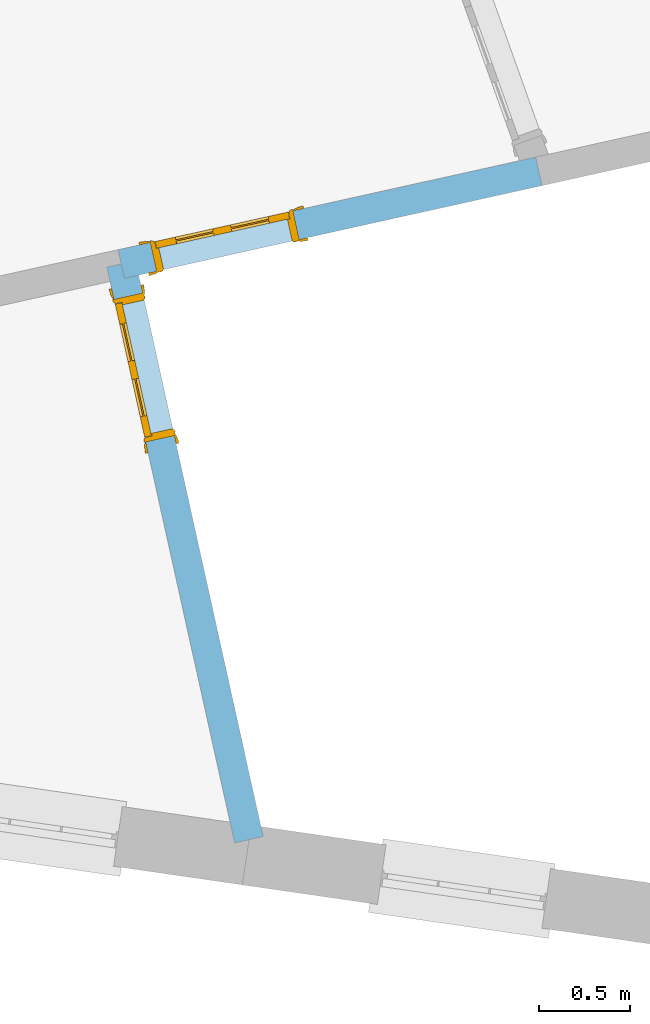
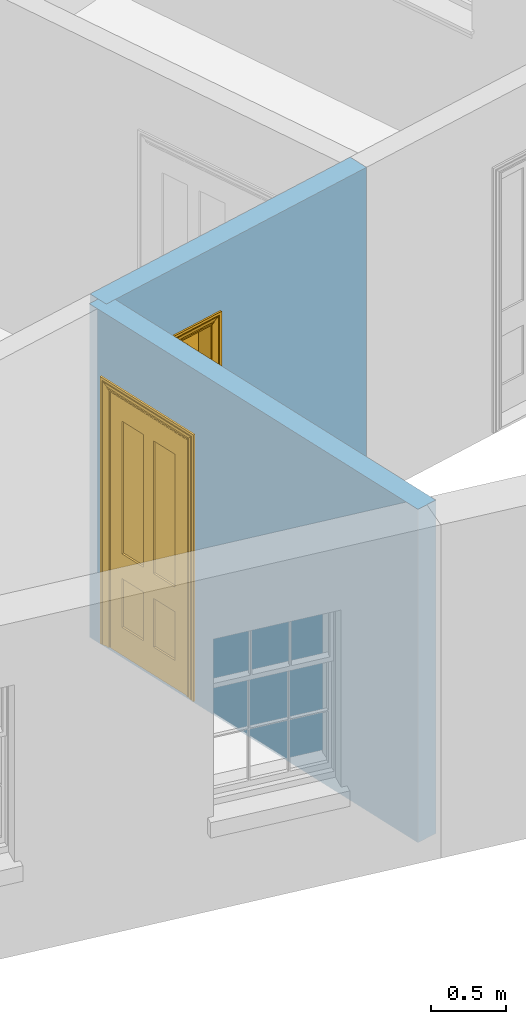
# One storey, part 6 of 11: 2 doors, 2 openings, plus 2 elements that do not belong to this part.
"""IFC2X3 building model written with IfcOpenShell, lengths in metres."""

from ifc_helpers import new_model, si_unit, frame, origin, place, context, subcontext, project, spatial, polyline, outline, extrude, faceted_brep, material, layer, layer_set, layer_usage, element, fill, save


model = new_model("IFC2X3")

# Units and contexts
model_context = context("Model", 3, world=origin())
body_context = subcontext(model_context, "Body", "Model", "MODEL_VIEW")
ifc_project = project(units=[si_unit("PLANEANGLEUNIT", "RADIAN"), si_unit("MASSUNIT", "GRAM", prefix="KILO"), si_unit("FORCEUNIT", "NEWTON", prefix="KILO"), si_unit("LENGTHUNIT", "METRE")], contexts=[model_context])

# Site, building, storey
site_placement = place(None, origin())
site = spatial("IfcSite", under=ifc_project, at=site_placement, CompositionType="ELEMENT")
building_placement = place(None, origin())
building = spatial("IfcBuilding", under=site, at=building_placement, Name="Building plot-16", CompositionType="ELEMENT")
storey_placement = place(None, frame((0.0, 0.0, 9.0)))
storey = spatial("IfcBuildingStorey", under=building, at=storey_placement, Name="Floor 2", CompositionType="ELEMENT", Elevation=9.0)

# Wall, opening, door
ifc_material = material(Name="Masonry")
ifc_layer = layer(ifc_material, 0.16, ventilated=False)
ifc_layer_set = layer_set([ifc_layer], Name="My Wall")
ifc_layer_usage = layer_usage(ifc_layer_set, "AXIS2", "NEGATIVE", 0.08)
wall_1_placement = place(storey_placement, origin())
wall_1 = element("IfcWallStandardCase", 1, at=wall_1_placement, inside=storey, material=ifc_layer_usage, Name="interior", context=body_context, shape_type="SweptSolid", body=[
    extrude(outline(polyline([(92.4243994850158, 31.3164839815775), (92.580604620015, 31.3511243597489), (91.8820901630794, 34.5009613651233), (91.7258850280802, 34.4663209869519), (92.4243994850158, 31.3164839815775)])), origin(), (0.0, 0.0, 1.0), 2.7),
])
opening_1_placement = place(storey_placement, frame((0.0, 0.0, 0.0199999999999996)))
opening_1 = element("IfcOpeningElement", 2, at=opening_1_placement, cuts=wall_1, Name="Opening", ObjectType="Opening", context=body_context, shape_type="SweptSolid", body=[
    extrude(outline(polyline([(92.0942624793795, 33.5442049132528), (91.9210605885223, 34.3252305882491), (91.764855453523, 34.2905902100777), (91.9380573443802, 33.5095645350814), (92.0942624793795, 33.5442049132528)])), origin(), (0.0, 0.0, 1.0), 2.1),
])
door_1_placement = place(storey_placement, frame((92.0161599118799, 33.5268847241671, 0.0199999999999996), z_axis=(0.0, 0.0, 1.0), x_axis=(-0.1732018908572, 0.781025674996343, 0.0)))
door_1 = element("IfcDoor", 3, at=door_1_placement, inside=storey, Name="toilet inside door", OverallHeight=2.1, OverallWidth=0.8, context=body_context, shape_type="Brep", held_by="IfcProductRepresentation", body=[
    faceted_brep([(0.773, 0.08, 1.895), (0.66, 0.08, 1.895), (0.66, 0.08, 2.073), (0.773, 0.08, 2.073), (0.773, 0.08, 0.82), (0.66, 0.08, 0.82), (0.45, 0.08, 1.895), (0.45, 0.08, 2.073), (0.773, 0.08, 0.62), (0.66, 0.08, 0.62), (0.66, 0.065, 0.82), (0.66, 0.065, 1.895), (0.45, 0.065, 1.895), (0.35, 0.08, 1.895), (0.35, 0.08, 2.073), (0.773, 0.08, 0.225), (0.66, 0.08, 0.225), (0.45, 0.08, 0.62), (0.45, 0.08, 0.82), (0.45, 0.065, 0.82), (0.35, 0.08, 0.82), (0.14, 0.08, 2.073), (0.14, 0.08, 1.895), (0.773, 0.08, 0.0), (0.66, 0.08, 0.0), (0.66, 0.065, 0.225), (0.66, 0.065, 0.62), (0.45, 0.065, 0.62), (0.35, 0.08, 0.62), (0.35, 0.065, 0.82), (0.35, 0.065, 1.895), (0.14, 0.065, 1.895), (0.027, 0.08, 2.073), (0.027, 0.08, 1.895), (0.773, 0.042, 0.0), (0.66, 0.042, 0.0), (0.45, 0.08, 0.0), (0.45, 0.08, 0.225), (0.45, 0.065, 0.225), (0.35, 0.08, 0.225), (0.14, 0.08, 0.82), (0.14, 0.08, 0.62), (0.14, 0.065, 0.82), (0.027, 0.08, 0.82), (0.773, 0.042, 0.225), (0.66, 0.042, 0.225), (0.45, 0.042, 0.0), (0.35, 0.08, 0.0), (0.35, 0.065, 0.225), (0.35, 0.065, 0.62), (0.14, 0.065, 0.62), (0.027, 0.08, 0.62), (0.773, 0.042, 0.62), (0.66, 0.042, 0.62), (0.45, 0.042, 0.225), (0.35, 0.042, 0.0), (0.14, 0.08, 0.225), (0.14, 0.08, 0.0), (0.14, 0.065, 0.225), (0.027, 0.08, 0.225), (0.773, 0.042, 0.82), (0.66, 0.042, 0.82), (0.66, 0.057, 0.62), (0.66, 0.057, 0.225), (0.45, 0.057, 0.225), (0.35, 0.042, 0.225), (0.14, 0.042, 0.0), (0.027, 0.08, 0.0), (0.773, 0.042, 1.895), (0.66, 0.042, 1.895), (0.45, 0.042, 0.62), (0.45, 0.042, 0.82), (0.45, 0.057, 0.62), (0.35, 0.042, 0.62), (0.14, 0.042, 0.225), (0.027, 0.042, 0.0), (0.773, 0.042, 2.073), (0.66, 0.042, 2.073), (0.66, 0.057, 1.895), (0.66, 0.057, 0.82), (0.45, 0.057, 0.82), (0.35, 0.042, 0.82), (0.35, 0.057, 0.62), (0.35, 0.057, 0.225), (0.14, 0.057, 0.225), (0.027, 0.042, 0.225), (0.45, 0.042, 1.895), (0.45, 0.042, 2.073), (0.45, 0.057, 1.895), (0.35, 0.042, 1.895), (0.14, 0.042, 0.82), (0.14, 0.042, 0.62), (0.14, 0.057, 0.62), (0.027, 0.042, 0.62), (0.35, 0.042, 2.073), (0.35, 0.057, 1.895), (0.35, 0.057, 0.82), (0.14, 0.057, 0.82), (0.027, 0.042, 0.82), (0.14, 0.042, 2.073), (0.14, 0.042, 1.895), (0.14, 0.057, 1.895), (0.027, 0.042, 1.895), (0.027, 0.042, 2.073), (0.02, 0.085, 0.0), (0.005, 0.09, 0.0), (0.005, 0.09, 2.095), (0.02, 0.085, 2.08), (0.02, 0.08, 0.0), (0.0, 0.085, 0.0), (0.0, 0.085, 2.1), (0.795, 0.09, 2.095), (0.78, 0.085, 2.08), (0.02, 0.08, 2.08), (0.0, 0.08, 0.0), (-0.032, 0.095, 0.0), (-0.032, 0.095, 2.132), (0.8, 0.085, 2.1), (0.795, 0.09, 0.0), (0.78, 0.085, 0.0), (0.78, 0.08, 2.08), (0.04, 0.04, 0.0), (0.025, 0.04, 0.0), (0.025, 0.04, 2.075), (0.04, 0.04, 2.06), (-0.04, 0.09, 0.0), (-0.04, 0.09, 2.14), (0.832, 0.095, 2.132), (0.8, 0.085, 0.0), (0.78, 0.08, 0.0), (0.8, 0.08, 0.0), (0.86, 0.08, 0.0), (0.86, 0.08, 2.16), (0.8, 0.08, 2.1), (-0.06, 0.08, 2.16), (0.0, 0.08, 2.1), (-0.06, 0.08, 0.0), (-0.04, 0.095, 0.0), (-0.04, 0.095, 2.14), (0.84, 0.09, 2.14), (0.832, 0.095, 0.0), (0.84, 0.09, 0.0), (0.86, 0.095, 0.0), (0.86, 0.095, 2.16), (-0.06, 0.095, 2.16), (-0.06, 0.095, 0.0), (0.84, 0.095, 0.0), (0.84, 0.095, 2.14), (-0.025, -0.095, 0.0), (-0.025, -0.09, 0.0), (-0.025, -0.09, 2.125), (-0.025, -0.095, 2.125), (-0.017, -0.095, 0.0), (-0.017, -0.095, 2.117), (0.825, -0.09, 2.125), (0.825, -0.095, 2.125), (0.825, -0.095, 0.0), (0.845, -0.095, 0.0), (-0.045, -0.095, 2.145), (-0.045, -0.095, 0.0), (0.845, -0.095, 2.145), (0.015, -0.085, 0.0), (0.015, -0.085, 2.085), (0.817, -0.095, 2.117), (0.825, -0.09, 0.0), (0.845, -0.08, 0.0), (0.845, -0.08, 2.145), (-0.045, -0.08, 2.145), (-0.045, -0.08, 0.0), (0.02, -0.09, 0.0), (0.02, -0.09, 2.08), (0.785, -0.085, 2.085), (0.817, -0.095, 0.0), (0.8, -0.08, 0.0), (0.8, -0.08, 2.1), (0.0, -0.08, 2.1), (0.0, -0.08, 0.0), (0.035, -0.085, 0.0), (0.035, -0.085, 2.065), (0.78, -0.09, 2.08), (0.785, -0.085, 0.0), (0.775, 0.04, 2.075), (0.76, 0.04, 2.06), (0.035, -0.08, 2.065), (0.035, -0.08, 0.0), (0.765, -0.085, 2.065), (0.78, -0.09, 0.0), (0.765, -0.08, 0.0), (0.765, -0.08, 2.065), (0.765, -0.085, 0.0), (0.04, -0.08, 2.06), (0.04, -0.08, 0.0), (0.76, -0.08, 2.06), (0.76, -0.08, 0.0), (0.76, 0.04, 0.0), (0.775, 0.04, 0.0), (0.025, 0.08, 0.0), (0.025, 0.08, 2.075), (0.775, 0.08, 0.0), (0.775, 0.08, 2.075)], [[[0, 1, 2, 3]], [[1, 0, 4, 5]], [[1, 6, 7, 2]], [[8, 9, 5, 4]], [[1, 5, 10, 11]], [[6, 1, 11, 12]], [[6, 13, 14, 7]], [[15, 16, 9, 8]], [[9, 17, 18, 5]], [[5, 18, 19, 10]], [[10, 19, 12, 11]], [[18, 6, 12, 19]], [[18, 20, 13, 6]], [[21, 14, 13, 22]], [[23, 24, 16, 15]], [[9, 16, 25, 26]], [[17, 9, 26, 27]], [[17, 28, 20, 18]], [[13, 20, 29, 30]], [[22, 13, 30, 31]], [[32, 21, 22, 33]], [[34, 35, 24, 23]], [[24, 36, 37, 16]], [[16, 37, 38, 25]], [[25, 38, 27, 26]], [[37, 17, 27, 38]], [[37, 39, 28, 17]], [[40, 20, 28, 41]], [[20, 40, 42, 29]], [[31, 30, 29, 42]], [[40, 22, 31, 42]], [[33, 22, 40, 43]], [[35, 34, 44, 45]], [[35, 46, 36, 24]], [[36, 47, 39, 37]], [[28, 39, 48, 49]], [[41, 28, 49, 50]], [[43, 40, 41, 51]], [[45, 44, 52, 53]], [[46, 35, 45, 54]], [[46, 55, 47, 36]], [[56, 39, 47, 57]], [[39, 56, 58, 48]], [[50, 49, 48, 58]], [[56, 41, 50, 58]], [[51, 41, 56, 59]], [[53, 52, 60, 61]], [[45, 53, 62, 63]], [[54, 45, 63, 64]], [[55, 46, 54, 65]], [[55, 66, 57, 47]], [[59, 56, 57, 67]], [[61, 60, 68, 69]], [[70, 53, 61, 71]], [[53, 70, 72, 62]], [[72, 64, 63, 62]], [[70, 54, 64, 72]], [[65, 54, 70, 73]], [[65, 74, 66, 55]], [[67, 57, 66, 75]], [[69, 68, 76, 77]], [[61, 69, 78, 79]], [[71, 61, 79, 80]], [[73, 70, 71, 81]], [[65, 73, 82, 83]], [[74, 65, 83, 84]], [[74, 85, 75, 66]], [[86, 69, 77, 87]], [[69, 86, 88, 78]], [[88, 80, 79, 78]], [[86, 71, 80, 88]], [[81, 71, 86, 89]], [[73, 81, 90, 91]], [[73, 91, 92, 82]], [[83, 82, 92, 84]], [[91, 74, 84, 92]], [[91, 93, 85, 74]], [[89, 86, 87, 94]], [[81, 89, 95, 96]], [[90, 81, 96, 97]], [[90, 98, 93, 91]], [[94, 99, 100, 89]], [[89, 100, 101, 95]], [[101, 97, 96, 95]], [[100, 90, 97, 101]], [[100, 102, 98, 90]], [[99, 103, 102, 100]], [[32, 103, 99, 21]], [[102, 103, 32, 33]], [[98, 102, 33, 43]], [[21, 99, 94, 14]], [[94, 87, 7, 14]], [[7, 87, 77, 2]], [[76, 3, 2, 77]], [[43, 51, 93, 98]], [[51, 59, 85, 93]], [[67, 75, 85, 59]], [[34, 23, 15, 44]], [[44, 15, 8, 52]], [[52, 8, 4, 60]], [[0, 68, 60, 4]], [[0, 3, 76, 68]], [[104, 105, 106, 107]], [[104, 108, 109, 105]], [[105, 109, 110, 106]], [[107, 106, 111, 112]], [[107, 113, 108, 104]], [[114, 109, 108]], [[109, 115, 116, 110]], [[106, 110, 117, 111]], [[112, 111, 118, 119]], [[113, 107, 112, 120]], [[121, 122, 123, 124]], [[115, 109, 114, 125]], [[115, 125, 126, 116]], [[110, 116, 127, 117]], [[111, 117, 128, 118]], [[118, 128, 129, 119]], [[120, 112, 119, 129]], [[130, 129, 128]], [[130, 131, 132, 133]], [[133, 132, 134, 135]], [[135, 134, 136, 114]], [[136, 125, 114]], [[125, 137, 138, 126]], [[116, 126, 139, 127]], [[117, 127, 140, 128]], [[141, 130, 128, 140]], [[131, 130, 141]], [[131, 142, 143, 132]], [[132, 143, 144, 134]], [[134, 144, 145, 136]], [[137, 125, 136, 145]], [[143, 142, 146]], [[143, 146, 147]], [[137, 145, 144]], [[143, 147, 138]], [[138, 137, 144]], [[143, 138, 144]], [[126, 138, 147, 139]], [[127, 139, 141, 140]], [[142, 131, 141, 146]], [[139, 147, 146, 141]], [[148, 149, 150, 151]], [[149, 152, 153, 150]], [[151, 150, 154, 155]], [[155, 156, 157]], [[158, 159, 148]], [[158, 148, 151]], [[155, 157, 160]], [[158, 151, 155]], [[155, 160, 158]], [[152, 161, 162, 153]], [[150, 153, 163, 154]], [[155, 154, 164, 156]], [[156, 164, 165, 157]], [[157, 165, 166, 160]], [[160, 166, 167, 158]], [[158, 167, 168, 159]], [[161, 169, 170, 162]], [[153, 162, 171, 163]], [[154, 163, 172, 164]], [[165, 164, 173]], [[165, 173, 174, 166]], [[166, 174, 175, 167]], [[167, 175, 176, 168]], [[169, 177, 178, 170]], [[162, 170, 179, 171]], [[163, 171, 180, 172]], [[172, 180, 173, 164]], [[124, 123, 181, 182]], [[183, 178, 177, 184]], [[170, 178, 185, 179]], [[171, 179, 186, 180]], [[187, 173, 180]], [[185, 188, 187, 189]], [[188, 185, 178, 183]], [[179, 185, 189, 186]], [[189, 187, 180, 186]], [[190, 183, 184, 191]], [[192, 188, 183, 190]], [[191, 184, 122, 121]], [[124, 190, 191, 121]], [[193, 187, 188, 192]], [[182, 192, 190, 124]], [[184, 176, 122]], [[194, 195, 187, 193]], [[192, 182, 194, 193]], [[161, 176, 184]], [[114, 108, 122, 176]], [[173, 187, 195]], [[152, 149, 176, 161]], [[169, 161, 184, 177]], [[196, 122, 108]], [[176, 175, 135, 114]], [[173, 195, 129, 130]], [[176, 149, 168]], [[123, 122, 196, 197]], [[196, 108, 113, 197]], [[175, 174, 133, 135]], [[198, 129, 195]], [[133, 174, 173, 130]], [[159, 168, 149, 148]], [[181, 123, 197, 199]], [[197, 113, 120, 199]], [[199, 120, 129, 198]], [[195, 181, 199, 198]], [[195, 194, 182, 181]]]),
])
fill(opening_1, door_1)

wall_2_placement = place(storey_placement, origin())
wall_2 = element("IfcWallStandardCase", 4, at=wall_2_placement, inside=storey, material=ifc_layer_usage, Name="interior", context=body_context, shape_type="SweptSolid", body=[
    extrude(outline(polyline([(91.7866674064941, 34.5617437435372), (91.8213077846655, 34.405538608538), (94.1061893742812, 34.9122387393731), (94.0715489961098, 35.0684438743723), (91.7866674064941, 34.5617437435372)])), origin(), (0.0, 0.0, 1.0), 2.7),
])
opening_2_placement = place(storey_placement, frame((0.0, 0.0, 0.0199999999999996)))
opening_2 = element("IfcOpeningElement", 5, at=opening_2_placement, cuts=wall_2, Name="Opening", ObjectType="Opening", context=body_context, shape_type="SweptSolid", body=[
    extrude(outline(polyline([(91.9970385615397, 34.4445090339808), (92.778064236536, 34.617710924838), (92.7434238583646, 34.7739160598373), (91.9623981833683, 34.6007141689801), (91.9970385615397, 34.4445090339808)])), origin(), (0.0, 0.0, 1.0), 2.1),
])
door_2_placement = place(storey_placement, frame((91.979718372454, 34.5226116014805, 0.0199999999999996), z_axis=(0.0, 0.0, 1.0), x_axis=(0.781025674996343, 0.173201890857186, 0.0)))
door_2 = element("IfcDoor", 6, at=door_2_placement, inside=storey, Name="living inside door", OverallHeight=2.1, OverallWidth=0.8, context=body_context, shape_type="Brep", held_by="IfcProductRepresentation", body=[
    faceted_brep([(0.773, 0.08, 1.895), (0.66, 0.08, 1.895), (0.66, 0.08, 2.073), (0.773, 0.08, 2.073), (0.773, 0.08, 0.82), (0.66, 0.08, 0.82), (0.45, 0.08, 1.895), (0.45, 0.08, 2.073), (0.773, 0.08, 0.62), (0.66, 0.08, 0.62), (0.66, 0.065, 0.82), (0.66, 0.065, 1.895), (0.45, 0.065, 1.895), (0.35, 0.08, 1.895), (0.35, 0.08, 2.073), (0.773, 0.08, 0.225), (0.66, 0.08, 0.225), (0.45, 0.08, 0.62), (0.45, 0.08, 0.82), (0.45, 0.065, 0.82), (0.35, 0.08, 0.82), (0.14, 0.08, 2.073), (0.14, 0.08, 1.895), (0.773, 0.08, 0.0), (0.66, 0.08, 0.0), (0.66, 0.065, 0.225), (0.66, 0.065, 0.62), (0.45, 0.065, 0.62), (0.35, 0.08, 0.62), (0.35, 0.065, 0.82), (0.35, 0.065, 1.895), (0.14, 0.065, 1.895), (0.027, 0.08, 2.073), (0.027, 0.08, 1.895), (0.773, 0.042, 0.0), (0.66, 0.042, 0.0), (0.45, 0.08, 0.0), (0.45, 0.08, 0.225), (0.45, 0.065, 0.225), (0.35, 0.08, 0.225), (0.14, 0.08, 0.82), (0.14, 0.08, 0.62), (0.14, 0.065, 0.82), (0.027, 0.08, 0.82), (0.773, 0.042, 0.225), (0.66, 0.042, 0.225), (0.45, 0.042, 0.0), (0.35, 0.08, 0.0), (0.35, 0.065, 0.225), (0.35, 0.065, 0.62), (0.14, 0.065, 0.62), (0.027, 0.08, 0.62), (0.773, 0.042, 0.62), (0.66, 0.042, 0.62), (0.45, 0.042, 0.225), (0.35, 0.042, 0.0), (0.14, 0.08, 0.225), (0.14, 0.08, 0.0), (0.14, 0.065, 0.225), (0.027, 0.08, 0.225), (0.773, 0.042, 0.82), (0.66, 0.042, 0.82), (0.66, 0.057, 0.62), (0.66, 0.057, 0.225), (0.45, 0.057, 0.225), (0.35, 0.042, 0.225), (0.14, 0.042, 0.0), (0.027, 0.08, 0.0), (0.773, 0.042, 1.895), (0.66, 0.042, 1.895), (0.45, 0.042, 0.62), (0.45, 0.042, 0.82), (0.45, 0.057, 0.62), (0.35, 0.042, 0.62), (0.14, 0.042, 0.225), (0.027, 0.042, 0.0), (0.773, 0.042, 2.073), (0.66, 0.042, 2.073), (0.66, 0.057, 1.895), (0.66, 0.057, 0.82), (0.45, 0.057, 0.82), (0.35, 0.042, 0.82), (0.35, 0.057, 0.62), (0.35, 0.057, 0.225), (0.14, 0.057, 0.225), (0.027, 0.042, 0.225), (0.45, 0.042, 1.895), (0.45, 0.042, 2.073), (0.45, 0.057, 1.895), (0.35, 0.042, 1.895), (0.14, 0.042, 0.82), (0.14, 0.042, 0.62), (0.14, 0.057, 0.62), (0.027, 0.042, 0.62), (0.35, 0.042, 2.073), (0.35, 0.057, 1.895), (0.35, 0.057, 0.82), (0.14, 0.057, 0.82), (0.027, 0.042, 0.82), (0.14, 0.042, 2.073), (0.14, 0.042, 1.895), (0.14, 0.057, 1.895), (0.027, 0.042, 1.895), (0.027, 0.042, 2.073), (0.02, 0.085, 0.0), (0.005, 0.09, 0.0), (0.005, 0.09, 2.095), (0.02, 0.085, 2.08), (0.02, 0.08, 0.0), (0.0, 0.085, 0.0), (0.0, 0.085, 2.1), (0.795, 0.09, 2.095), (0.78, 0.085, 2.08), (0.02, 0.08, 2.08), (0.0, 0.08, 0.0), (-0.032, 0.095, 0.0), (-0.032, 0.095, 2.132), (0.8, 0.085, 2.1), (0.795, 0.09, 0.0), (0.78, 0.085, 0.0), (0.78, 0.08, 2.08), (0.04, 0.04, 0.0), (0.025, 0.04, 0.0), (0.025, 0.04, 2.075), (0.04, 0.04, 2.06), (-0.04, 0.09, 0.0), (-0.04, 0.09, 2.14), (0.832, 0.095, 2.132), (0.8, 0.085, 0.0), (0.78, 0.08, 0.0), (0.8, 0.08, 0.0), (0.86, 0.08, 0.0), (0.86, 0.08, 2.16), (0.8, 0.08, 2.1), (-0.06, 0.08, 2.16), (0.0, 0.08, 2.1), (-0.06, 0.08, 0.0), (-0.04, 0.095, 0.0), (-0.04, 0.095, 2.14), (0.84, 0.09, 2.14), (0.832, 0.095, 0.0), (0.84, 0.09, 0.0), (0.86, 0.095, 0.0), (0.86, 0.095, 2.16), (-0.06, 0.095, 2.16), (-0.06, 0.095, 0.0), (0.84, 0.095, 0.0), (0.84, 0.095, 2.14), (-0.025, -0.095, 0.0), (-0.025, -0.09, 0.0), (-0.025, -0.09, 2.125), (-0.025, -0.095, 2.125), (-0.017, -0.095, 0.0), (-0.017, -0.095, 2.117), (0.825, -0.09, 2.125), (0.825, -0.095, 2.125), (0.825, -0.095, 0.0), (0.845, -0.095, 0.0), (-0.045, -0.095, 2.145), (-0.045, -0.095, 0.0), (0.845, -0.095, 2.145), (0.015, -0.085, 0.0), (0.015, -0.085, 2.085), (0.817, -0.095, 2.117), (0.825, -0.09, 0.0), (0.845, -0.08, 0.0), (0.845, -0.08, 2.145), (-0.045, -0.08, 2.145), (-0.045, -0.08, 0.0), (0.02, -0.09, 0.0), (0.02, -0.09, 2.08), (0.785, -0.085, 2.085), (0.817, -0.095, 0.0), (0.8, -0.08, 0.0), (0.8, -0.08, 2.1), (0.0, -0.08, 2.1), (0.0, -0.08, 0.0), (0.035, -0.085, 0.0), (0.035, -0.085, 2.065), (0.78, -0.09, 2.08), (0.785, -0.085, 0.0), (0.775, 0.04, 2.075), (0.76, 0.04, 2.06), (0.035, -0.08, 2.065), (0.035, -0.08, 0.0), (0.765, -0.085, 2.065), (0.78, -0.09, 0.0), (0.765, -0.08, 0.0), (0.765, -0.08, 2.065), (0.765, -0.085, 0.0), (0.04, -0.08, 2.06), (0.04, -0.08, 0.0), (0.76, -0.08, 2.06), (0.76, -0.08, 0.0), (0.76, 0.04, 0.0), (0.775, 0.04, 0.0), (0.025, 0.08, 0.0), (0.025, 0.08, 2.075), (0.775, 0.08, 0.0), (0.775, 0.08, 2.075)], [[[0, 1, 2, 3]], [[1, 0, 4, 5]], [[1, 6, 7, 2]], [[8, 9, 5, 4]], [[1, 5, 10, 11]], [[6, 1, 11, 12]], [[6, 13, 14, 7]], [[15, 16, 9, 8]], [[9, 17, 18, 5]], [[5, 18, 19, 10]], [[10, 19, 12, 11]], [[18, 6, 12, 19]], [[18, 20, 13, 6]], [[21, 14, 13, 22]], [[23, 24, 16, 15]], [[9, 16, 25, 26]], [[17, 9, 26, 27]], [[17, 28, 20, 18]], [[13, 20, 29, 30]], [[22, 13, 30, 31]], [[32, 21, 22, 33]], [[34, 35, 24, 23]], [[24, 36, 37, 16]], [[16, 37, 38, 25]], [[25, 38, 27, 26]], [[37, 17, 27, 38]], [[37, 39, 28, 17]], [[40, 20, 28, 41]], [[20, 40, 42, 29]], [[31, 30, 29, 42]], [[40, 22, 31, 42]], [[33, 22, 40, 43]], [[35, 34, 44, 45]], [[35, 46, 36, 24]], [[36, 47, 39, 37]], [[28, 39, 48, 49]], [[41, 28, 49, 50]], [[43, 40, 41, 51]], [[45, 44, 52, 53]], [[46, 35, 45, 54]], [[46, 55, 47, 36]], [[56, 39, 47, 57]], [[39, 56, 58, 48]], [[50, 49, 48, 58]], [[56, 41, 50, 58]], [[51, 41, 56, 59]], [[53, 52, 60, 61]], [[45, 53, 62, 63]], [[54, 45, 63, 64]], [[55, 46, 54, 65]], [[55, 66, 57, 47]], [[59, 56, 57, 67]], [[61, 60, 68, 69]], [[70, 53, 61, 71]], [[53, 70, 72, 62]], [[72, 64, 63, 62]], [[70, 54, 64, 72]], [[65, 54, 70, 73]], [[65, 74, 66, 55]], [[67, 57, 66, 75]], [[69, 68, 76, 77]], [[61, 69, 78, 79]], [[71, 61, 79, 80]], [[73, 70, 71, 81]], [[65, 73, 82, 83]], [[74, 65, 83, 84]], [[74, 85, 75, 66]], [[86, 69, 77, 87]], [[69, 86, 88, 78]], [[88, 80, 79, 78]], [[86, 71, 80, 88]], [[81, 71, 86, 89]], [[73, 81, 90, 91]], [[73, 91, 92, 82]], [[83, 82, 92, 84]], [[91, 74, 84, 92]], [[91, 93, 85, 74]], [[89, 86, 87, 94]], [[81, 89, 95, 96]], [[90, 81, 96, 97]], [[90, 98, 93, 91]], [[94, 99, 100, 89]], [[89, 100, 101, 95]], [[101, 97, 96, 95]], [[100, 90, 97, 101]], [[100, 102, 98, 90]], [[99, 103, 102, 100]], [[32, 103, 99, 21]], [[102, 103, 32, 33]], [[98, 102, 33, 43]], [[21, 99, 94, 14]], [[94, 87, 7, 14]], [[7, 87, 77, 2]], [[76, 3, 2, 77]], [[43, 51, 93, 98]], [[51, 59, 85, 93]], [[67, 75, 85, 59]], [[34, 23, 15, 44]], [[44, 15, 8, 52]], [[52, 8, 4, 60]], [[0, 68, 60, 4]], [[0, 3, 76, 68]], [[104, 105, 106, 107]], [[104, 108, 109, 105]], [[105, 109, 110, 106]], [[107, 106, 111, 112]], [[107, 113, 108, 104]], [[114, 109, 108]], [[109, 115, 116, 110]], [[106, 110, 117, 111]], [[112, 111, 118, 119]], [[113, 107, 112, 120]], [[121, 122, 123, 124]], [[115, 109, 114, 125]], [[115, 125, 126, 116]], [[110, 116, 127, 117]], [[111, 117, 128, 118]], [[118, 128, 129, 119]], [[120, 112, 119, 129]], [[130, 129, 128]], [[130, 131, 132, 133]], [[133, 132, 134, 135]], [[135, 134, 136, 114]], [[136, 125, 114]], [[125, 137, 138, 126]], [[116, 126, 139, 127]], [[117, 127, 140, 128]], [[141, 130, 128, 140]], [[131, 130, 141]], [[131, 142, 143, 132]], [[132, 143, 144, 134]], [[134, 144, 145, 136]], [[137, 125, 136, 145]], [[143, 142, 146]], [[143, 146, 147]], [[137, 145, 144]], [[143, 147, 138]], [[138, 137, 144]], [[143, 138, 144]], [[126, 138, 147, 139]], [[127, 139, 141, 140]], [[142, 131, 141, 146]], [[139, 147, 146, 141]], [[148, 149, 150, 151]], [[149, 152, 153, 150]], [[151, 150, 154, 155]], [[155, 156, 157]], [[158, 159, 148]], [[158, 148, 151]], [[155, 157, 160]], [[158, 151, 155]], [[155, 160, 158]], [[152, 161, 162, 153]], [[150, 153, 163, 154]], [[155, 154, 164, 156]], [[156, 164, 165, 157]], [[157, 165, 166, 160]], [[160, 166, 167, 158]], [[158, 167, 168, 159]], [[161, 169, 170, 162]], [[153, 162, 171, 163]], [[154, 163, 172, 164]], [[165, 164, 173]], [[165, 173, 174, 166]], [[166, 174, 175, 167]], [[167, 175, 176, 168]], [[169, 177, 178, 170]], [[162, 170, 179, 171]], [[163, 171, 180, 172]], [[172, 180, 173, 164]], [[124, 123, 181, 182]], [[183, 178, 177, 184]], [[170, 178, 185, 179]], [[171, 179, 186, 180]], [[187, 173, 180]], [[185, 188, 187, 189]], [[188, 185, 178, 183]], [[179, 185, 189, 186]], [[189, 187, 180, 186]], [[190, 183, 184, 191]], [[192, 188, 183, 190]], [[191, 184, 122, 121]], [[124, 190, 191, 121]], [[193, 187, 188, 192]], [[182, 192, 190, 124]], [[184, 176, 122]], [[194, 195, 187, 193]], [[192, 182, 194, 193]], [[161, 176, 184]], [[114, 108, 122, 176]], [[173, 187, 195]], [[152, 149, 176, 161]], [[169, 161, 184, 177]], [[196, 122, 108]], [[176, 175, 135, 114]], [[173, 195, 129, 130]], [[176, 149, 168]], [[123, 122, 196, 197]], [[196, 108, 113, 197]], [[175, 174, 133, 135]], [[198, 129, 195]], [[133, 174, 173, 130]], [[159, 168, 149, 148]], [[181, 123, 197, 199]], [[197, 113, 120, 199]], [[199, 120, 129, 198]], [[195, 181, 199, 198]], [[195, 194, 182, 181]]]),
])
fill(opening_2, door_2)

save(model, "model.ifc")
